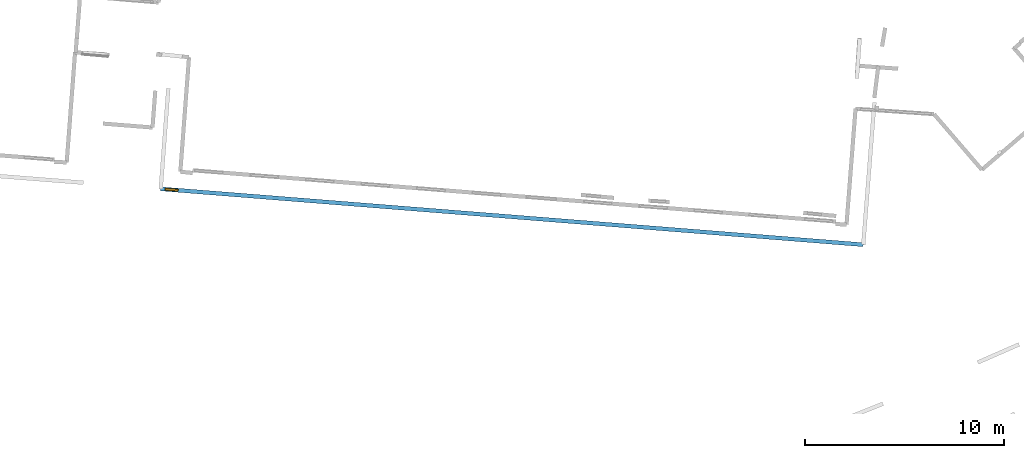
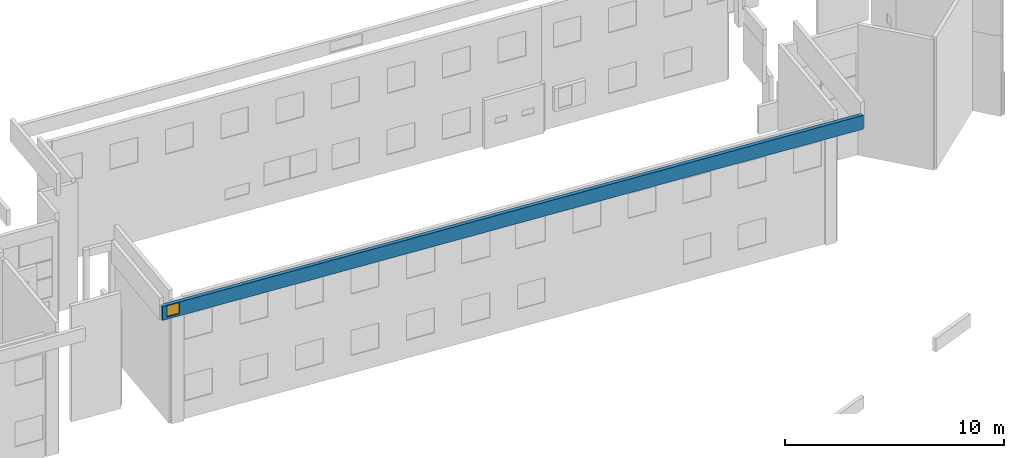
# One storey, part 17 of 27: 1 wall, 1 window, 1 opening.
"""IFC2X3 building model written with IfcOpenShell, lengths in metres."""

from ifc_helpers import new_model, entity, si_unit, converted_unit, derived_unit, direction, frame, frame_2d, origin, origin_2d_with_axis, place, context, subcontext, project, spatial, polyline, rectangle, outline, extrude, source, transform, mapped, material, layer, layer_set, layer_usage, type_object, type_shapes, element, fill, save


model = new_model("IFC2X3")

# Units and contexts
model_context = context("Model", 3, precision=1e-05, world=origin(), true_north=direction((0.0, 1.0)))
body_context = subcontext(model_context, "Body", "Model", "MODEL_VIEW")
ifc_project = project(units=[si_unit("LENGTHUNIT", "METRE"), si_unit("AREAUNIT", "SQUARE_METRE"), si_unit("VOLUMEUNIT", "CUBIC_METRE"), converted_unit("PLANEANGLEUNIT", "DEGREE", entity("IfcRatioMeasure", 0.0174532925199433), si_unit("PLANEANGLEUNIT", "RADIAN"), dimensions=[0, 0, 0, 0, 0, 0, 0]), si_unit("MASSUNIT", "GRAM", prefix="KILO"), derived_unit("MASSDENSITYUNIT", [(si_unit("MASSUNIT", "GRAM", prefix="KILO"), 1), (si_unit("LENGTHUNIT", "METRE"), -3)]), derived_unit("MOMENTOFINERTIAUNIT", [(si_unit("LENGTHUNIT", "METRE"), 4)]), si_unit("TIMEUNIT", "SECOND"), si_unit("FREQUENCYUNIT", "HERTZ"), si_unit("THERMODYNAMICTEMPERATUREUNIT", "DEGREE_CELSIUS"), derived_unit("THERMALTRANSMITTANCEUNIT", [(si_unit("MASSUNIT", "GRAM", prefix="KILO"), 1), (si_unit("THERMODYNAMICTEMPERATUREUNIT", "KELVIN"), -1), (si_unit("TIMEUNIT", "SECOND"), -3)]), derived_unit("VOLUMETRICFLOWRATEUNIT", [(si_unit("LENGTHUNIT", "METRE"), 3), (si_unit("TIMEUNIT", "SECOND"), -1)]), si_unit("ELECTRICCURRENTUNIT", "AMPERE"), si_unit("ELECTRICVOLTAGEUNIT", "VOLT"), si_unit("POWERUNIT", "WATT"), si_unit("FORCEUNIT", "NEWTON", prefix="KILO"), si_unit("ILLUMINANCEUNIT", "LUX"), si_unit("LUMINOUSFLUXUNIT", "LUMEN"), si_unit("LUMINOUSINTENSITYUNIT", "CANDELA"), derived_unit("USERDEFINED", [(si_unit("MASSUNIT", "GRAM", prefix="KILO"), -1), (si_unit("LENGTHUNIT", "METRE"), -2), (si_unit("TIMEUNIT", "SECOND"), 3), (si_unit("LUMINOUSFLUXUNIT", "LUMEN"), 1)]), derived_unit("LINEARVELOCITYUNIT", [(si_unit("LENGTHUNIT", "METRE"), 1), (si_unit("TIMEUNIT", "SECOND"), -1)]), si_unit("PRESSUREUNIT", "PASCAL"), derived_unit("USERDEFINED", [(si_unit("LENGTHUNIT", "METRE"), -2), (si_unit("MASSUNIT", "GRAM", prefix="KILO"), 1), (si_unit("TIMEUNIT", "SECOND"), -2)]), derived_unit("LINEARFORCEUNIT", [(si_unit("MASSUNIT", "GRAM", prefix="KILO"), 1), (si_unit("LENGTHUNIT", "METRE"), 1), (si_unit("TIMEUNIT", "SECOND"), -2), (si_unit("LENGTHUNIT", "METRE"), -1)]), derived_unit("PLANARFORCEUNIT", [(si_unit("MASSUNIT", "GRAM", prefix="KILO"), 1), (si_unit("LENGTHUNIT", "METRE"), 1), (si_unit("TIMEUNIT", "SECOND"), -2), (si_unit("LENGTHUNIT", "METRE"), -2)])], contexts=[model_context])

# Site, building, storey
placement_1 = place(None, origin())
site = spatial("IfcSite", under=ifc_project, at=placement_1, CompositionType="ELEMENT")
building = spatial("IfcBuilding", under=site, at=placement_1, CompositionType="ELEMENT")
storey_placement = place(placement_1, frame((0.0, 0.0, -61.043098449707)))
storey = spatial("IfcBuildingStorey", under=building, at=storey_placement, Name="level_-61.043098", CompositionType="ELEMENT", Elevation=-61.043098449707)

# Wall, opening, window
ifc_material_1 = material(Name="Default wall")
ifc_layer = layer(ifc_material_1, 0.2)
ifc_layer_set = layer_set([ifc_layer], Name="wall_thickness_0.2000")
ifc_layer_usage = layer_usage(ifc_layer_set, "AXIS2", "POSITIVE", -0.1)
wall_type = type_object("IfcWallType", Name="wall_thickness_0.2000", PredefinedType="STANDARD", material=ifc_layer_set)
placement_2 = place(placement_1, frame((0.0, 0.0, -54.4207000732422)))
wall_placement = place(placement_2, frame((-32.298864865168, -17.3784635109606, 0.0), z_axis=(0.0, 0.0, 1.0), x_axis=(0.996854347329349, -0.0792553481512597, 0.0)))
wall = element("IfcWallStandardCase", 1, at=wall_placement, inside=storey, type_object=wall_type, material=ifc_layer_usage, Name="Wall:640", ObjectType="Wall", context=body_context, shape_type="SweptSolid", body=[
    extrude(outline(polyline([(35.3833938254747, -0.1), (35.3833938254747, 0.1), (0.0, 0.1), (0.0, -0.1), (35.3833938254747, -0.1)])), origin(), (0.0, 0.0, 1.0), 0.772296905517578),
])
opening_placement = place(wall_placement, frame((0.236006265937598, -0.1, 0.128242492675781)))
opening = element("IfcOpeningElement", 2, at=opening_placement, cuts=wall, Name="Opening : 635 x 615 : 54", ObjectType="Opening", context=body_context, shape_type="SweptSolid", body=[
    extrude(rectangle(XDim=0.635, YDim=0.615, at=frame_2d((0.3075, 0.3175), x_axis=(0.0, 1.0))), frame((0.0, 0.0, 0.0), z_axis=(0.0, 1.0, 0.0), x_axis=(0.0, 0.0, 1.0)), (0.0, 0.0, 1.0), 0.2),
])
ifc_material_2 = material(Name="Window Default")
window_style = type_object("IfcWindowStyle", Name="Window : 635 x 615mm", ConstructionType="NOTDEFINED", OperationType="NOTDEFINED", ParameterTakesPrecedence=False, Sizeable=False, material=ifc_material_2)
shared_shape = source(origin(), body_context, "Body", "SweptSolid", [
    extrude(rectangle(XDim=0.1, YDim=0.635, at=origin_2d_with_axis()), frame((0.3175, 0.1, 0.0), z_axis=(0.0, 0.0, 1.0), x_axis=(0.0, 1.0, 0.0)), (0.0, 0.0, 1.0), 0.615),
])
type_shapes(window_style, [shared_shape])
window_placement = place(opening_placement, origin())
window = element("IfcWindow", 3, at=window_placement, inside=storey, type_object=window_style, Name="Window : 635 x 615mm : 46", ObjectType="Window : 635 x 615mm", OverallHeight=0.615, OverallWidth=0.635, context=body_context, shape_type="MappedRepresentation", body=[
    mapped(shared_shape, transform((0.0, 0.0, 0.0), scale=1.0)),
])
fill(opening, window)

save(model, "model.ifc")
